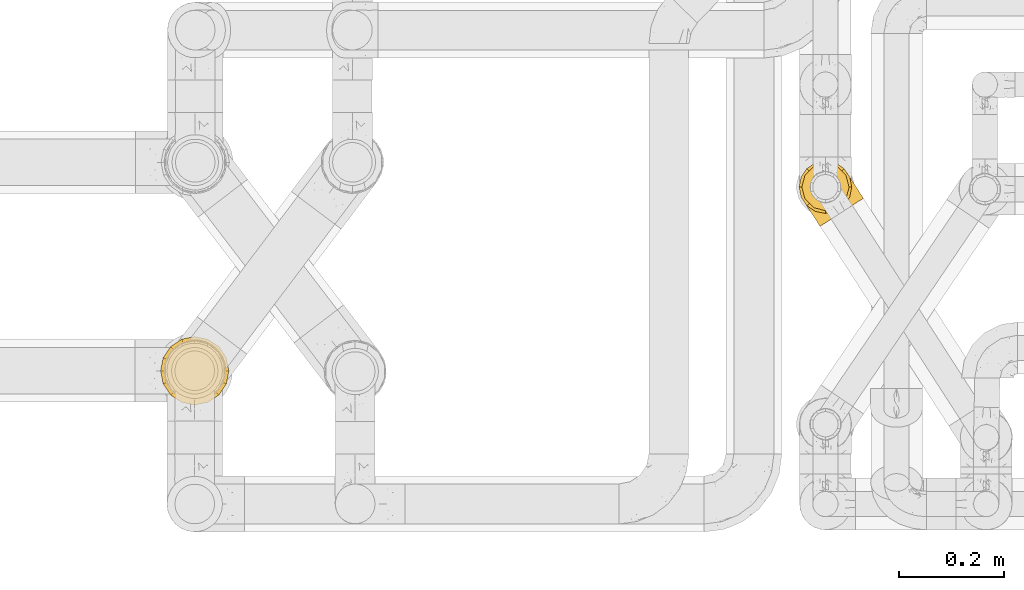
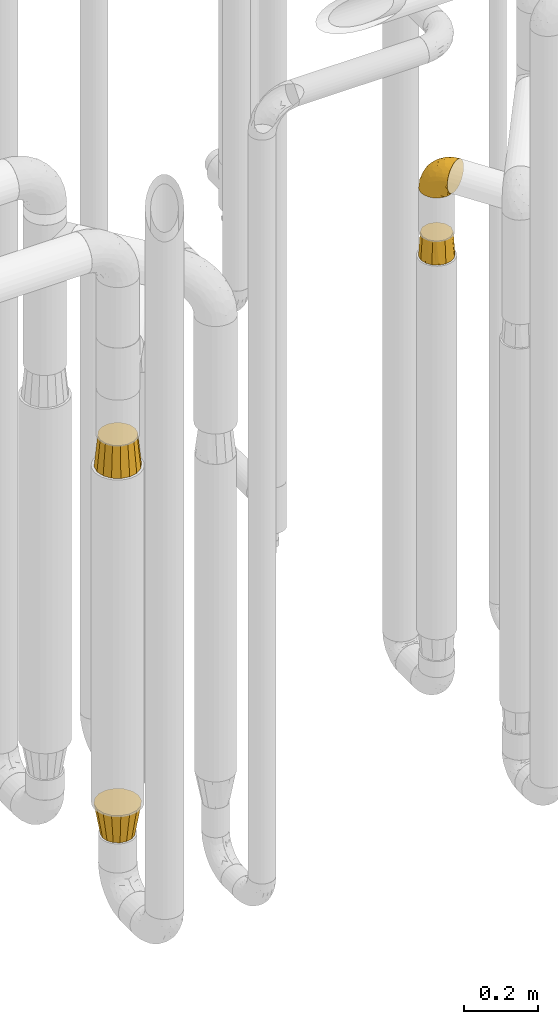
# One storey, part 379 of 827: 4 coverings.
"""IFC2X3 building model written with IfcOpenShell, lengths in millimetres."""

from ifc_helpers import new_model, entity, si_unit, converted_unit, derived_unit, direction, frame, origin, place, context, subcontext, project, spatial, faceted_brep, element, save


model = new_model("IFC2X3")

# Units and contexts
model_context = context("Model", 3, precision=0.01, world=origin(), true_north=direction((6.12303176911189e-17, 1.0)))
body_context = subcontext(model_context, "Body", "Model", "MODEL_VIEW")
ifc_project = project(units=[si_unit("LENGTHUNIT", "METRE", prefix="MILLI"), si_unit("AREAUNIT", "SQUARE_METRE"), si_unit("VOLUMEUNIT", "CUBIC_METRE"), converted_unit("PLANEANGLEUNIT", "DEGREE", entity("IfcRatioMeasure", 0.0174532925199433), si_unit("PLANEANGLEUNIT", "RADIAN"), dimensions=[0, 0, 0, 0, 0, 0, 0]), si_unit("MASSUNIT", "GRAM", prefix="KILO"), derived_unit("MASSDENSITYUNIT", [(si_unit("MASSUNIT", "GRAM", prefix="KILO"), 1), (si_unit("LENGTHUNIT", "METRE"), -3)]), derived_unit("MOMENTOFINERTIAUNIT", [(si_unit("LENGTHUNIT", "METRE"), 4)]), si_unit("TIMEUNIT", "SECOND"), si_unit("FREQUENCYUNIT", "HERTZ"), si_unit("THERMODYNAMICTEMPERATUREUNIT", "DEGREE_CELSIUS"), derived_unit("THERMALTRANSMITTANCEUNIT", [(si_unit("MASSUNIT", "GRAM", prefix="KILO"), 1), (si_unit("THERMODYNAMICTEMPERATUREUNIT", "KELVIN"), -1), (si_unit("TIMEUNIT", "SECOND"), -3)]), derived_unit("VOLUMETRICFLOWRATEUNIT", [(si_unit("LENGTHUNIT", "METRE"), 3), (si_unit("TIMEUNIT", "SECOND"), -1)]), derived_unit("MASSFLOWRATEUNIT", [(si_unit("MASSUNIT", "GRAM", prefix="KILO"), 1), (si_unit("TIMEUNIT", "SECOND"), -1)]), derived_unit("ROTATIONALFREQUENCYUNIT", [(si_unit("TIMEUNIT", "SECOND"), -1)]), si_unit("ELECTRICCURRENTUNIT", "AMPERE"), si_unit("ELECTRICVOLTAGEUNIT", "VOLT"), si_unit("POWERUNIT", "WATT"), si_unit("FORCEUNIT", "NEWTON", prefix="KILO"), si_unit("ILLUMINANCEUNIT", "LUX"), si_unit("LUMINOUSFLUXUNIT", "LUMEN"), si_unit("LUMINOUSINTENSITYUNIT", "CANDELA"), derived_unit("USERDEFINED", [(si_unit("MASSUNIT", "GRAM", prefix="KILO"), -1), (si_unit("LENGTHUNIT", "METRE"), -2), (si_unit("TIMEUNIT", "SECOND"), 3), (si_unit("LUMINOUSFLUXUNIT", "LUMEN"), 1)]), derived_unit("LINEARVELOCITYUNIT", [(si_unit("LENGTHUNIT", "METRE"), 1), (si_unit("TIMEUNIT", "SECOND"), -1)]), si_unit("PRESSUREUNIT", "PASCAL"), derived_unit("USERDEFINED", [(si_unit("LENGTHUNIT", "METRE"), -2), (si_unit("MASSUNIT", "GRAM", prefix="KILO"), 1), (si_unit("TIMEUNIT", "SECOND"), -2)]), derived_unit("LINEARFORCEUNIT", [(si_unit("MASSUNIT", "GRAM", prefix="KILO"), 1), (si_unit("LENGTHUNIT", "METRE"), 1), (si_unit("TIMEUNIT", "SECOND"), -2), (si_unit("LENGTHUNIT", "METRE"), -1)]), derived_unit("PLANARFORCEUNIT", [(si_unit("MASSUNIT", "GRAM", prefix="KILO"), 1), (si_unit("LENGTHUNIT", "METRE"), 1), (si_unit("TIMEUNIT", "SECOND"), -2), (si_unit("LENGTHUNIT", "METRE"), -2)])], contexts=[model_context])

# Site, building, storey
site_placement = place(None, origin())
site = spatial("IfcSite", under=ifc_project, at=site_placement, CompositionType="ELEMENT")
building_placement = place(site_placement, origin())
building = spatial("IfcBuilding", under=site, at=building_placement, CompositionType="ELEMENT")
storey_placement = place(building_placement, frame((0.0, 0.0, 28200.0)))
storey = spatial("IfcBuildingStorey", under=building, at=storey_placement, Name="08", CompositionType="ELEMENT", Elevation=28200.0)

# Coverings
covering_1_placement = place(storey_placement, frame((46641.19, 14187.93, 1821.5)))
element("IfcCovering", 1, at=covering_1_placement, inside=storey, Name=":ADSK_", ObjectType=":ADSK_", PredefinedType="INSULATION", context=body_context, shape_type="Brep", body=[
    faceted_brep([(62.85, 93.58, 76.0), (51.6, 96.6, 76.0), (40.35, 93.58, 76.0), (29.1, 90.57, 76.0), (20.86, 82.33, 76.0), (12.62, 74.1, 76.0), (9.61, 62.85, 76.0), (6.6, 51.6, 76.0), (9.61, 40.35, 76.0), (12.62, 29.1, 76.0), (20.86, 20.86, 76.0), (29.1, 12.62, 76.0), (40.35, 9.61, 76.0), (51.6, 6.6, 76.0), (62.85, 9.61, 76.0), (74.1, 12.62, 76.0), (82.33, 20.86, 76.0), (90.57, 29.1, 76.0), (93.58, 40.35, 76.0), (96.6, 51.6, 76.0), (93.58, 62.85, 76.0), (90.57, 74.1, 76.0), (82.33, 82.33, 76.0), (74.1, 90.57, 76.0), (97.79, 32.46, 0.0), (92.37, 24.35, 0.0), (86.95, 16.24, 0.0), (78.84, 10.82, 0.0), (70.73, 5.4, 0.0), (61.16, 3.5, 0.0), (51.6, 1.6, 0.0), (42.03, 3.5, 0.0), (32.46, 5.4, 0.0), (24.35, 10.82, 0.0), (16.24, 16.24, 0.0), (10.82, 24.35, 0.0), (5.4, 32.46, 0.0), (3.5, 42.03, 0.0), (1.6, 51.6, 0.0), (3.5, 61.16, 0.0), (5.4, 70.73, 0.0), (10.82, 78.84, 0.0), (16.24, 86.95, 0.0), (24.35, 92.37, 0.0), (32.46, 97.79, 0.0), (42.03, 99.69, 0.0), (51.6, 101.6, 0.0), (61.16, 99.69, 0.0), (70.73, 97.79, 0.0), (78.84, 92.37, 0.0), (86.95, 86.95, 0.0), (92.37, 78.84, 0.0), (97.79, 70.73, 0.0), (99.69, 61.16, 0.0), (101.6, 51.6, 0.0), (99.69, 42.03, 0.0)], [[[0, 1, 2, 3, 4, 5, 6, 7, 8, 9, 10, 11, 12, 13, 14, 15, 16, 17, 18, 19, 20, 21, 22, 23]], [[24, 25, 26, 27, 28, 29, 30, 31, 32, 33, 34, 35, 36, 37, 38, 39, 40, 41, 42, 43, 44, 45, 46, 47, 48, 49, 50, 51, 52, 53, 54, 55]], [[39, 38, 7]], [[41, 40, 5]], [[41, 5, 4]], [[3, 43, 4]], [[41, 4, 42]], [[45, 1, 46]], [[7, 6, 39]], [[43, 42, 4]], [[1, 45, 2]], [[6, 5, 40]], [[6, 40, 39]], [[44, 3, 2]], [[45, 44, 2]], [[3, 44, 43]], [[31, 30, 13]], [[33, 32, 11]], [[33, 11, 10]], [[9, 35, 10]], [[33, 10, 34]], [[37, 7, 38]], [[13, 12, 31]], [[35, 34, 10]], [[7, 37, 8]], [[12, 11, 32]], [[12, 32, 31]], [[36, 9, 8]], [[37, 36, 8]], [[9, 36, 35]], [[55, 54, 19]], [[25, 24, 17]], [[25, 17, 16]], [[15, 27, 16]], [[25, 16, 26]], [[29, 13, 30]], [[19, 18, 55]], [[27, 26, 16]], [[13, 29, 14]], [[18, 17, 24]], [[18, 24, 55]], [[28, 15, 14]], [[29, 28, 14]], [[15, 28, 27]], [[47, 46, 1]], [[49, 48, 23]], [[49, 23, 22]], [[21, 51, 22]], [[49, 22, 50]], [[53, 19, 54]], [[1, 0, 47]], [[51, 50, 22]], [[19, 53, 20]], [[0, 23, 48]], [[0, 48, 47]], [[52, 21, 20]], [[53, 52, 20]], [[21, 52, 51]]]),
])
covering_2_placement = place(storey_placement, frame((46642.11, 14163.37, 2041.52)))
element("IfcCovering", 2, at=covering_2_placement, inside=storey, Name=":ADSK_", ObjectType=":ADSK_", PredefinedType="INSULATION", context=body_context, shape_type="Brep", body=[
    faceted_brep([(122.92, 55.05, 58.6), (121.89, 54.38, 69.54), (118.84, 52.4, 79.93), (113.92, 49.22, 89.25), (107.39, 44.98, 97.03), (99.57, 39.92, 102.88), (90.85, 34.27, 106.51), (81.68, 28.32, 107.75), (72.49, 22.37, 106.51), (63.77, 16.72, 102.87), (55.95, 11.65, 97.02), (49.42, 7.42, 89.23), (44.51, 4.24, 79.91), (41.46, 2.26, 69.53), (40.43, 1.6, 58.6), (40.97, 1.94, 52.89), (41.47, 2.27, 47.65), (42.99, 3.26, 42.46), (44.52, 4.24, 37.26), (49.43, 7.43, 27.94), (55.97, 11.66, 20.16), (63.79, 16.73, 14.31), (72.5, 22.38, 10.68), (81.68, 28.32, 9.45), (90.86, 34.27, 10.68), (99.58, 39.92, 14.32), (107.4, 44.99, 20.17), (113.93, 49.22, 27.96), (118.84, 52.41, 37.28), (120.37, 53.39, 42.47), (121.89, 54.38, 47.66), (122.39, 54.7, 52.89), (122.66, 54.88, 55.75), (65.82, 29.4, 1.6), (53.2, 27.07, 1.6), (46.81, 27.58, 1.6), (40.41, 28.09, 1.6), (34.37, 30.24, 1.6), (28.32, 32.39, 1.6), (23.04, 36.03, 1.6), (17.76, 39.67, 1.6), (13.19, 45.03, 1.6), (11.31, 47.23, 1.6), (9.43, 49.43, 1.6), (3.92, 61.02, 1.6), (1.6, 73.63, 1.6), (2.61, 86.42, 1.6), (6.91, 98.52, 1.6), (14.19, 109.08, 1.6), (23.95, 117.41, 1.6), (35.54, 122.92, 1.6), (48.16, 125.24, 1.6), (60.95, 124.22, 1.6), (73.04, 119.93, 1.6), (83.6, 112.65, 1.6), (91.93, 102.89, 1.6), (94.41, 97.66, 1.6), (97.44, 91.3, 1.6), (98.6, 84.99, 1.6), (99.77, 78.68, 1.6), (99.26, 72.29, 1.6), (98.75, 65.89, 1.6), (96.6, 59.85, 1.6), (94.45, 53.8, 1.6), (87.17, 43.23, 1.6), (77.41, 34.91, 1.6), (45.24, 100.3, 69.96), (55.59, 109.64, 59.59), (42.83, 112.13, 51.96), (26.78, 113.05, 34.4), (32.16, 119.26, 23.37), (24.99, 115.8, 13.68), (54.4, 118.22, 41.52), (41.43, 121.58, 26.26), (53.4, 123.77, 20.18), (98.2, 82.94, 72.33), (110.78, 71.7, 65.88), (99.67, 88.18, 57.55), (77.07, 116.01, 23.76), (74.22, 111.86, 46.5), (87.02, 103.89, 46.57), (86.93, 108.56, 21.17), (94.29, 99.25, 23.41), (93.69, 100.16, 17.92), (93.1, 101.08, 12.43), (92.81, 101.53, 9.72), (92.51, 101.98, 7.01), (65.47, 120.59, 26.77), (109.64, 67.67, 76.59), (64.09, 73.28, 95.55), (80.38, 56.97, 102.57), (76.88, 76.4, 92.89), (111.06, 73.36, 54.26), (108.55, 77.24, 51.17), (106.03, 81.12, 48.08), (103.52, 85.0, 44.99), (101.01, 88.88, 41.9), (104.83, 65.97, 85.16), (58.49, 86.9, 85.97), (83.25, 101.57, 59.58), (92.27, 57.05, 99.5), (75.11, 38.47, 105.83), (64.96, 111.93, 53.59), (75.18, 101.49, 67.0), (65.87, 100.86, 71.56), (47.75, 80.68, 87.47), (41.36, 90.54, 75.73), (95.07, 67.0, 92.24), (121.45, 57.33, 58.06), (119.98, 59.6, 57.52), (117.03, 64.15, 56.44), (114.05, 68.75, 55.35), (89.47, 83.22, 81.33), (77.23, 90.54, 80.35), (93.29, 99.45, 39.44), (63.84, 55.85, 102.55), (99.33, 91.47, 37.28), (97.65, 94.06, 32.65), (95.97, 96.65, 28.03), (34.98, 100.39, 63.99), (56.16, 98.71, 74.55), (67.5, 89.75, 83.62), (55.79, 68.27, 95.01), (30.88, 106.72, 49.19), (117.2, 61.68, 46.96), (96.52, 94.18, 8.77), (98.31, 91.01, 18.28), (97.98, 90.59, 11.68), (94.09, 41.82, 11.79), (100.27, 47.58, 15.69), (110.91, 71.09, 42.49), (112.43, 70.14, 47.41), (98.67, 62.46, 7.94), (100.25, 70.87, 9.27), (95.48, 53.04, 7.98), (100.46, 62.07, 13.4), (97.7, 49.83, 13.04), (89.08, 42.7, 7.36), (105.33, 65.55, 23.46), (107.88, 68.58, 30.46), (108.11, 60.4, 26.54), (100.06, 74.32, 6.76), (109.94, 54.41, 26.46), (105.14, 53.46, 20.77), (103.57, 69.94, 20.68), (114.79, 62.03, 40.26), (78.66, 32.98, 7.15), (86.56, 35.92, 9.28), (108.0, 75.28, 38.78), (102.81, 56.7, 18.27), (105.12, 78.16, 31.78), (100.21, 82.11, 12.75), (99.52, 89.08, 22.96), (101.39, 79.76, 17.55), (102.33, 83.42, 27.63), (101.68, 70.85, 15.23), (112.96, 58.69, 33.25), (110.37, 63.88, 32.43), (100.29, 88.52, 27.9), (53.49, 25.83, 7.97), (34.7, 27.44, 15.22), (43.57, 26.76, 7.93), (43.21, 24.98, 13.38), (62.39, 20.75, 13.12), (30.69, 19.12, 42.49), (30.95, 17.33, 47.4), (26.05, 23.78, 51.17), (37.39, 11.87, 40.24), (49.16, 17.18, 20.76), (9.73, 48.98, 4.31), (10.61, 47.62, 12.43), (10.02, 48.53, 7.01), (46.33, 13.2, 26.44), (41.6, 17.32, 26.52), (18.18, 38.88, 11.68), (25.01, 33.38, 12.75), (32.19, 30.34, 6.76), (41.21, 12.18, 33.21), (37.51, 16.66, 32.41), (15.51, 41.68, 8.77), (18.93, 36.86, 22.96), (17.5, 38.91, 18.48), (34.54, 10.69, 56.44), (36.72, 9.54, 46.95), (65.52, 27.44, 7.36), (11.2, 46.7, 17.92), (11.79, 45.79, 23.41), (69.05, 25.45, 9.85), (37.48, 6.14, 57.52), (36.01, 8.42, 56.98), (23.54, 27.66, 48.08), (28.07, 23.48, 38.78), (47.15, 20.63, 18.25), (21.03, 31.54, 44.99), (26.62, 27.29, 31.74), (34.23, 20.87, 30.45), (22.96, 31.97, 27.63), (34.77, 25.34, 20.65), (31.55, 15.3, 55.35), (28.57, 19.9, 54.26), (55.52, 22.49, 13.03), (38.05, 21.95, 23.44), (19.13, 35.93, 27.9), (15.15, 40.6, 32.65), (26.68, 31.35, 17.55), (35.25, 28.76, 9.27), (13.47, 43.2, 28.03), (16.83, 38.01, 37.28), (18.51, 35.42, 41.9), (11.92, 47.07, 39.74), (18.91, 110.67, 23.37), (4.09, 80.81, 26.77), (8.38, 69.38, 46.18), (12.17, 77.72, 53.54), (10.77, 89.95, 41.53), (18.1, 85.29, 59.61), (34.53, 18.71, 76.79), (30.14, 19.68, 66.11), (6.3, 56.31, 21.17), (21.06, 98.02, 51.96), (13.0, 103.16, 26.26), (6.11, 93.13, 20.18), (3.52, 68.35, 23.76), (39.74, 52.33, 92.88), (56.05, 41.2, 102.57), (47.81, 62.75, 95.54), (21.96, 72.31, 71.63), (27.86, 80.37, 74.55), (25.37, 34.98, 72.51), (30.87, 90.99, 69.96), (40.9, 31.89, 92.23), (37.85, 22.57, 85.15), (26.79, 57.76, 80.45), (31.43, 66.38, 83.65), (19.69, 36.37, 57.57), (16.65, 52.24, 63.68), (37.7, 73.47, 85.95), (51.12, 30.39, 99.49), (28.29, 43.77, 81.23), (10.49, 54.9, 47.07), (17.54, 64.13, 66.99)], [[[0, 1, 2, 3, 4, 5, 6, 7, 8, 9, 10, 11, 12, 13, 14, 15, 16, 17, 18, 19, 20, 21, 22, 23, 24, 25, 26, 27, 28, 29, 30, 31, 32]], [[33, 34, 35, 36, 37, 38, 39, 40, 41, 42, 43, 44, 45, 46, 47, 48, 49, 50, 51, 52, 53, 54, 55, 56, 57, 58, 59, 60, 61, 62, 63, 64, 65]], [[66, 67, 68]], [[69, 70, 71]], [[68, 72, 73]], [[73, 72, 74]], [[75, 76, 77]], [[78, 79, 80]], [[51, 50, 73]], [[81, 82, 83, 84, 85, 86, 55]], [[52, 87, 53]], [[74, 52, 51]], [[2, 1, 88]], [[89, 90, 91]], [[77, 92, 93, 94, 95, 96]], [[55, 54, 81]], [[78, 53, 87]], [[5, 90, 6]], [[88, 76, 75]], [[97, 3, 2]], [[89, 91, 98]], [[99, 80, 79]], [[90, 5, 100]], [[74, 87, 52]], [[100, 5, 4]], [[90, 101, 6]], [[79, 102, 103]], [[102, 67, 104]], [[105, 98, 106]], [[107, 4, 3]], [[76, 0, 108, 109, 110, 111, 92]], [[107, 112, 113]], [[114, 77, 96]], [[89, 115, 90]], [[114, 96, 116, 117, 118, 82]], [[75, 97, 88]], [[119, 66, 68]], [[50, 71, 70]], [[100, 91, 90]], [[99, 77, 80]], [[102, 104, 103]], [[97, 107, 3]], [[80, 81, 78]], [[107, 97, 112]], [[68, 73, 70]], [[66, 98, 120]], [[78, 81, 54]], [[114, 81, 80]], [[53, 78, 54]], [[78, 87, 79]], [[102, 87, 72]], [[79, 103, 99]], [[4, 107, 100]], [[91, 100, 107]], [[88, 97, 2]], [[112, 97, 75]], [[99, 112, 75]], [[103, 104, 113]], [[91, 121, 98]], [[89, 105, 122, 115]], [[101, 90, 115]], [[101, 7, 6]], [[88, 1, 76]], [[0, 76, 1]], [[92, 77, 76]], [[73, 74, 51]], [[87, 74, 72]], [[81, 114, 82]], [[77, 114, 80]], [[87, 102, 79]], [[67, 102, 72]], [[68, 67, 72]], [[67, 120, 104]], [[120, 121, 104]], [[104, 121, 113]], [[121, 120, 98]], [[91, 107, 113]], [[91, 113, 121]], [[103, 113, 112]], [[106, 98, 66]], [[105, 89, 98]], [[106, 66, 119]], [[67, 66, 120]], [[68, 69, 123, 119]], [[50, 49, 71]], [[50, 70, 73]], [[112, 99, 103]], [[77, 99, 75]], [[69, 68, 70]], [[29, 124, 110]], [[84, 83, 125]], [[126, 82, 118]], [[59, 58, 127]], [[25, 128, 129]], [[130, 93, 131]], [[132, 62, 133]], [[134, 135, 136]], [[137, 65, 64]], [[64, 134, 137]], [[138, 139, 140]], [[111, 110, 124, 92]], [[134, 136, 137]], [[134, 64, 63]], [[133, 61, 141]], [[125, 58, 57]], [[142, 143, 140]], [[142, 26, 143]], [[127, 83, 82]], [[28, 124, 29]], [[108, 0, 32, 31, 30, 110, 109]], [[30, 29, 110]], [[135, 144, 138]], [[28, 145, 124]], [[57, 56, 55, 86, 85, 84]], [[146, 147, 23]], [[24, 23, 147]], [[25, 143, 26]], [[95, 94, 148]], [[24, 128, 25]], [[149, 138, 143]], [[124, 145, 131]], [[127, 58, 125]], [[150, 148, 139]], [[127, 126, 151]], [[151, 59, 127]], [[152, 151, 126]], [[153, 154, 155]], [[153, 133, 141]], [[145, 28, 27]], [[142, 156, 27]], [[157, 148, 130]], [[61, 133, 62]], [[134, 132, 135]], [[147, 128, 24]], [[65, 137, 146]], [[146, 137, 147]], [[128, 137, 136]], [[137, 128, 147]], [[128, 136, 129]], [[149, 129, 136]], [[25, 129, 143]], [[158, 152, 117]], [[152, 118, 117]], [[153, 151, 152]], [[158, 116, 154]], [[144, 150, 138]], [[153, 152, 158]], [[133, 153, 155]], [[133, 155, 132]], [[141, 61, 60]], [[135, 132, 155]], [[134, 63, 132]], [[144, 135, 155]], [[135, 138, 149]], [[155, 154, 144]], [[150, 154, 96]], [[154, 150, 144]], [[148, 94, 130]], [[82, 126, 127]], [[118, 152, 126]], [[150, 96, 95]], [[139, 148, 157]], [[150, 95, 148]], [[93, 92, 131]], [[130, 145, 156]], [[130, 94, 93]], [[84, 125, 57]], [[127, 125, 83]], [[140, 139, 157]], [[150, 139, 138]], [[140, 157, 142]], [[138, 140, 143]], [[156, 142, 157]], [[27, 26, 142]], [[130, 156, 157]], [[145, 27, 156]], [[132, 63, 62]], [[124, 131, 92]], [[130, 131, 145]], [[129, 149, 143]], [[135, 149, 136]], [[60, 151, 141]], [[59, 151, 60]], [[141, 151, 153]], [[116, 96, 154]], [[153, 158, 154]], [[158, 117, 116]], [[34, 33, 159]], [[160, 161, 162]], [[22, 21, 163]], [[164, 165, 166]], [[19, 18, 167]], [[168, 21, 20]], [[169, 43, 42, 41, 40, 170, 171]], [[172, 173, 168]], [[174, 38, 175]], [[37, 36, 176]], [[177, 164, 178]], [[40, 179, 170]], [[180, 181, 175]], [[17, 182, 183]], [[65, 146, 184]], [[185, 174, 186]], [[23, 22, 187]], [[174, 39, 38]], [[15, 14, 188, 189, 182, 16]], [[179, 40, 39]], [[190, 191, 164]], [[192, 163, 168]], [[33, 184, 159]], [[178, 173, 172]], [[193, 194, 191]], [[18, 183, 167]], [[173, 178, 195]], [[196, 197, 194]], [[198, 199, 183, 182]], [[182, 17, 16]], [[18, 17, 183]], [[200, 159, 184]], [[192, 168, 201]], [[187, 163, 200]], [[202, 203, 180]], [[185, 179, 174]], [[160, 204, 205]], [[206, 181, 180]], [[206, 180, 203]], [[199, 165, 183]], [[165, 164, 167]], [[172, 177, 178]], [[200, 192, 162]], [[205, 161, 160]], [[65, 184, 33]], [[163, 187, 22]], [[175, 204, 180]], [[174, 181, 186]], [[204, 196, 202]], [[197, 160, 162]], [[196, 207, 202]], [[37, 176, 175]], [[196, 204, 160]], [[176, 204, 175]], [[205, 35, 161]], [[34, 159, 161]], [[162, 161, 159]], [[200, 162, 159]], [[197, 162, 201]], [[194, 197, 201]], [[196, 160, 197]], [[191, 195, 178]], [[208, 196, 194]], [[186, 181, 206]], [[175, 181, 174]], [[191, 190, 193]], [[193, 208, 194]], [[195, 194, 201]], [[178, 164, 191]], [[168, 163, 21]], [[166, 165, 199]], [[166, 190, 164]], [[187, 200, 184]], [[184, 146, 187]], [[23, 187, 146]], [[174, 179, 39]], [[170, 179, 185]], [[194, 195, 191]], [[173, 201, 168]], [[201, 173, 195]], [[172, 168, 20]], [[20, 19, 172]], [[177, 172, 19]], [[19, 167, 177]], [[164, 177, 167]], [[35, 205, 36]], [[35, 34, 161]], [[183, 165, 167]], [[162, 192, 201]], [[163, 192, 200]], [[175, 38, 37]], [[36, 205, 176]], [[204, 176, 205]], [[204, 202, 180]], [[207, 196, 208]], [[207, 203, 202]], [[209, 186, 206, 203, 207, 208]], [[48, 210, 71]], [[211, 212, 213]], [[214, 213, 215]], [[216, 217, 13]], [[218, 43, 169, 171, 170, 185, 186]], [[219, 220, 214]], [[47, 46, 221]], [[210, 48, 220]], [[211, 222, 212]], [[222, 45, 44]], [[221, 220, 47]], [[47, 220, 48]], [[221, 211, 214]], [[223, 224, 225]], [[211, 46, 45]], [[226, 227, 215]], [[43, 218, 44]], [[217, 216, 228]], [[219, 215, 229]], [[14, 13, 217]], [[224, 9, 8]], [[10, 230, 11]], [[11, 231, 12]], [[232, 223, 233]], [[234, 208, 193, 190, 166, 199]], [[235, 234, 228]], [[222, 44, 218]], [[106, 229, 236]], [[224, 237, 9]], [[231, 238, 228]], [[9, 237, 10]], [[115, 224, 101]], [[239, 234, 235]], [[231, 11, 230]], [[223, 230, 237]], [[224, 8, 101]], [[223, 236, 233]], [[225, 115, 122, 105]], [[216, 12, 231]], [[209, 234, 239]], [[210, 219, 69]], [[219, 214, 215]], [[229, 119, 219]], [[209, 218, 186]], [[239, 212, 222]], [[239, 222, 218]], [[45, 222, 211]], [[235, 212, 239]], [[213, 212, 240]], [[223, 237, 224]], [[230, 10, 237]], [[238, 231, 230]], [[216, 231, 228]], [[232, 230, 223]], [[235, 238, 240]], [[115, 225, 224]], [[233, 236, 227]], [[8, 7, 101]], [[234, 209, 208]], [[218, 209, 239]], [[217, 228, 234]], [[13, 12, 216]], [[234, 199, 217]], [[217, 199, 198, 182, 189, 188, 14]], [[211, 221, 46]], [[220, 221, 214]], [[71, 210, 69]], [[71, 49, 48]], [[219, 210, 220]], [[226, 215, 213]], [[211, 213, 214]], [[226, 213, 240]], [[215, 227, 229]], [[232, 240, 238]], [[233, 227, 226]], [[232, 233, 226]], [[236, 223, 225]], [[240, 232, 226]], [[232, 238, 230]], [[225, 105, 236]], [[236, 105, 106]], [[236, 229, 227]], [[123, 69, 219, 119]], [[106, 119, 229]], [[238, 235, 228]], [[212, 235, 240]]]),
])
covering_3_placement = place(storey_placement, frame((45426.68, 13823.58, 541.02)))
element("IfcCovering", 3, at=covering_3_placement, inside=storey, Name=":ADSK_", ObjectType=":ADSK_", PredefinedType="INSULATION", context=body_context, shape_type="Brep", body=[
    faceted_brep([(131.6, 66.6, 102.0), (128.81, 80.58, 102.0), (126.65, 91.47, 102.0), (119.6, 102.01, 102.0), (112.56, 112.56, 102.0), (102.01, 119.6, 102.0), (91.47, 126.65, 102.0), (80.58, 128.81, 102.0), (66.6, 131.6, 102.0), (52.61, 128.81, 102.0), (41.72, 126.65, 102.0), (31.18, 119.6, 102.0), (20.63, 112.56, 102.0), (13.59, 102.01, 102.0), (6.54, 91.47, 102.0), (4.38, 80.58, 102.0), (1.6, 66.6, 102.0), (4.38, 52.61, 102.0), (6.54, 41.72, 102.0), (13.59, 31.18, 102.0), (20.63, 20.63, 102.0), (31.18, 13.59, 102.0), (41.72, 6.54, 102.0), (52.61, 4.38, 102.0), (66.6, 1.6, 102.0), (80.58, 4.38, 102.0), (91.47, 6.54, 102.0), (102.01, 13.59, 102.0), (112.56, 20.63, 102.0), (119.6, 31.18, 102.0), (126.65, 41.72, 102.0), (128.81, 52.61, 102.0), (48.42, 22.71, 0.0), (40.71, 27.86, 0.0), (33.01, 33.01, 0.0), (27.86, 40.71, 0.0), (22.71, 48.42, 0.0), (20.9, 57.51, 0.0), (19.1, 66.6, 0.0), (20.9, 75.68, 0.0), (22.71, 84.77, 0.0), (27.86, 92.48, 0.0), (33.01, 100.18, 0.0), (40.71, 105.33, 0.0), (48.42, 110.48, 0.0), (57.51, 112.29, 0.0), (66.6, 114.1, 0.0), (75.68, 112.29, 0.0), (84.77, 110.48, 0.0), (92.48, 105.33, 0.0), (100.18, 100.18, 0.0), (105.33, 92.48, 0.0), (110.48, 84.77, 0.0), (112.29, 75.68, 0.0), (114.1, 66.6, 0.0), (112.29, 57.51, 0.0), (110.48, 48.42, 0.0), (105.33, 40.71, 0.0), (100.18, 33.01, 0.0), (92.48, 27.86, 0.0), (84.77, 22.71, 0.0), (75.68, 20.9, 0.0), (66.6, 19.1, 0.0), (57.51, 20.9, 0.0)], [[[0, 1, 2, 3, 4, 5, 6, 7, 8, 9, 10, 11, 12, 13, 14, 15, 16, 17, 18, 19, 20, 21, 22, 23, 24, 25, 26, 27, 28, 29, 30, 31]], [[32, 33, 34, 35, 36, 37, 38, 39, 40, 41, 42, 43, 44, 45, 46, 47, 48, 49, 50, 51, 52, 53, 54, 55, 56, 57, 58, 59, 60, 61, 62, 63]], [[52, 2, 1, 0, 54, 53]], [[50, 4, 3, 2, 52, 51]], [[8, 7, 6, 48, 47, 46]], [[4, 50, 49, 48, 6, 5]], [[44, 10, 9, 8, 46, 45]], [[42, 12, 11, 10, 44, 43]], [[16, 15, 14, 40, 39, 38]], [[12, 42, 41, 40, 14, 13]], [[36, 18, 17, 16, 38, 37]], [[34, 20, 19, 18, 36, 35]], [[24, 23, 22, 32, 63, 62]], [[20, 34, 33, 32, 22, 21]], [[60, 26, 25, 24, 62, 61]], [[58, 28, 27, 26, 60, 59]], [[0, 31, 30, 56, 55, 54]], [[28, 58, 57, 56, 30, 29]]]),
])
covering_4_placement = place(storey_placement, frame((45426.68, 13823.58, 1758.0)))
element("IfcCovering", 4, at=covering_4_placement, inside=storey, Name=":ADSK_", ObjectType=":ADSK_", PredefinedType="INSULATION", context=body_context, shape_type="Brep", body=[
    faceted_brep([(117.41, 45.55, 102.0), (119.5, 56.07, 102.0), (121.6, 66.6, 102.0), (119.5, 77.12, 102.0), (117.41, 87.64, 102.0), (111.45, 96.56, 102.0), (105.49, 105.49, 102.0), (96.56, 111.45, 102.0), (87.64, 117.41, 102.0), (77.12, 119.5, 102.0), (66.6, 121.6, 102.0), (56.07, 119.5, 102.0), (45.55, 117.41, 102.0), (36.63, 111.45, 102.0), (27.7, 105.49, 102.0), (21.74, 96.56, 102.0), (15.78, 87.64, 102.0), (13.69, 77.12, 102.0), (11.6, 66.6, 102.0), (13.69, 56.07, 102.0), (15.78, 45.55, 102.0), (21.74, 36.63, 102.0), (27.7, 27.7, 102.0), (36.63, 21.74, 102.0), (45.55, 15.78, 102.0), (56.07, 13.69, 102.0), (66.6, 11.6, 102.0), (77.12, 13.69, 102.0), (87.64, 15.78, 102.0), (96.56, 21.74, 102.0), (105.49, 27.7, 102.0), (111.45, 36.63, 102.0), (112.56, 20.63, 0.0), (102.01, 13.59, 0.0), (91.47, 6.54, 0.0), (81.18, 4.5, 0.0), (66.6, 1.6, 0.0), (52.01, 4.5, 0.0), (41.72, 6.54, 0.0), (31.18, 13.59, 0.0), (20.63, 20.63, 0.0), (13.59, 31.18, 0.0), (6.54, 41.72, 0.0), (4.5, 52.01, 0.0), (1.6, 66.6, 0.0), (4.5, 81.18, 0.0), (6.54, 91.47, 0.0), (13.59, 102.01, 0.0), (20.63, 112.56, 0.0), (31.18, 119.6, 0.0), (41.72, 126.65, 0.0), (52.01, 128.69, 0.0), (66.6, 131.6, 0.0), (81.18, 128.69, 0.0), (91.47, 126.65, 0.0), (102.01, 119.6, 0.0), (112.56, 112.56, 0.0), (119.6, 102.01, 0.0), (126.65, 91.47, 0.0), (128.69, 81.18, 0.0), (131.6, 66.6, 0.0), (128.69, 52.01, 0.0), (126.65, 41.72, 0.0), (119.6, 31.18, 0.0)], [[[0, 1, 2, 3, 4, 5, 6, 7, 8, 9, 10, 11, 12, 13, 14, 15, 16, 17, 18, 19, 20, 21, 22, 23, 24, 25, 26, 27, 28, 29, 30, 31]], [[32, 33, 34, 35, 36, 37, 38, 39, 40, 41, 42, 43, 44, 45, 46, 47, 48, 49, 50, 51, 52, 53, 54, 55, 56, 57, 58, 59, 60, 61, 62, 63]], [[16, 46, 45, 44, 18, 17]], [[47, 46, 16, 15, 14, 48]], [[11, 10, 52, 51, 50, 12]], [[49, 48, 14, 13, 12, 50]], [[24, 38, 37, 36, 26, 25]], [[39, 38, 24, 23, 22, 40]], [[19, 18, 44, 43, 42, 20]], [[41, 40, 22, 21, 20, 42]], [[0, 62, 61, 60, 2, 1]], [[63, 62, 0, 31, 30, 32]], [[27, 26, 36, 35, 34, 28]], [[33, 32, 30, 29, 28, 34]], [[8, 54, 53, 52, 10, 9]], [[55, 54, 8, 7, 6, 56]], [[3, 2, 60, 59, 58, 4]], [[57, 56, 6, 5, 4, 58]]]),
])

save(model, "model.ifc")
